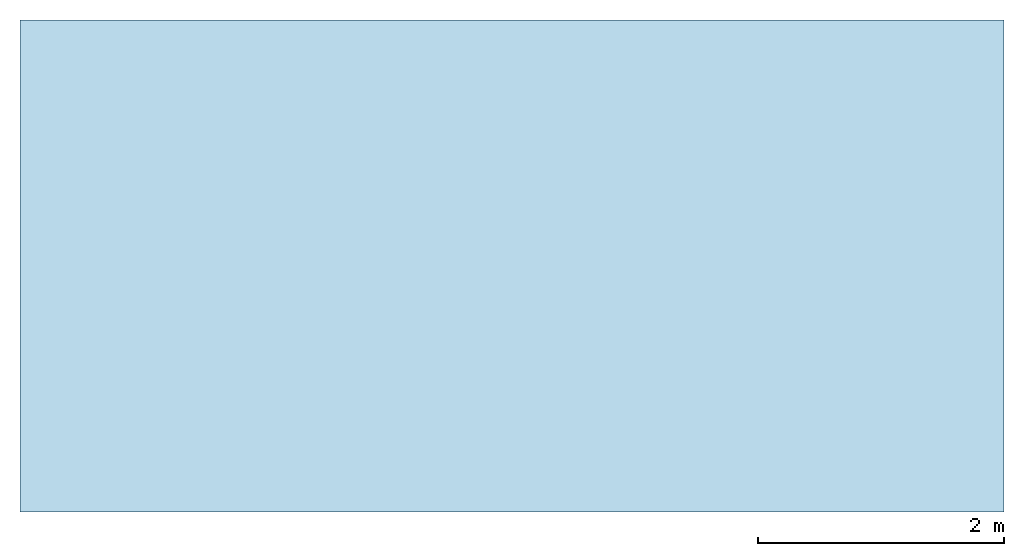
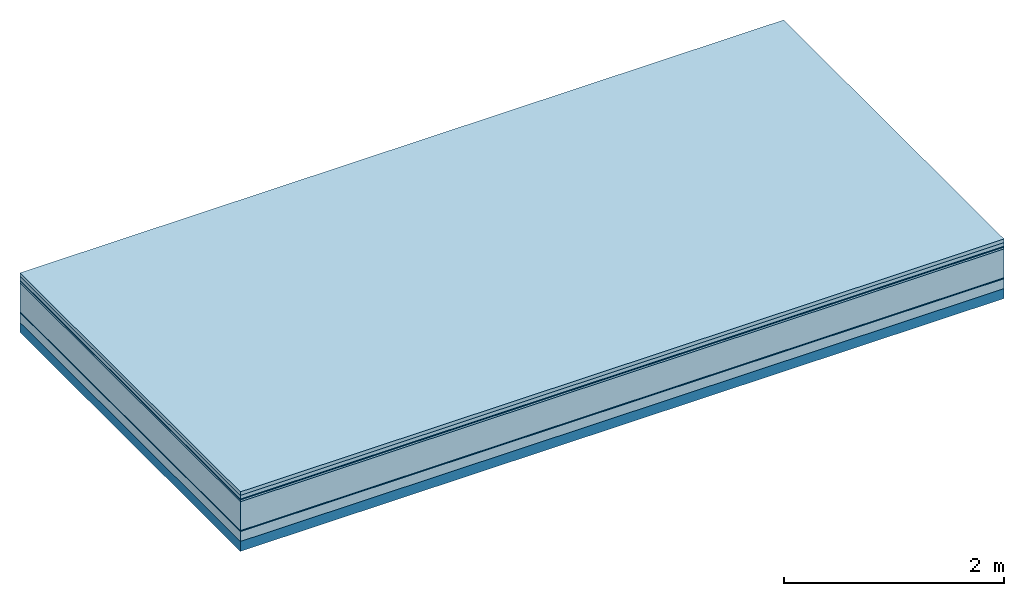
# One storey: 7 plates, 1 member, 1 element without a shape of its own.
"""IFC4 building model written with IfcOpenShell, lengths in metres."""

from ifc_helpers import new_model, si_unit, derived_unit, direction, frame, frame_2d, origin, origin_with_axes, place, context, project, spatial, rectangle, extrude, material, layer, layer_set, type_object, element, aggregate, save


model = new_model("IFC4")

# Units and contexts
plan_context = context("Plan", 3, precision=1e-05, world=origin(), true_north=direction((0.0, 1.0)))
model_context = context("Model", 3, precision=1e-05, world=origin(), true_north=direction((0.0, 1.0)))
ifc_project = project(units=[si_unit("LENGTHUNIT", "METRE"), derived_unit("SOUNDPRESSUREUNIT", [(si_unit("PRESSUREUNIT", "PASCAL", prefix="MICRO"), 0)]), si_unit("ENERGYUNIT", "JOULE", prefix="MEGA"), si_unit("MASSUNIT", "GRAM", prefix="KILO"), derived_unit("THERMALTRANSMITTANCEUNIT", [(si_unit("POWERUNIT", "WATT"), 1), (si_unit("AREAUNIT", "SQUARE_METRE"), -1), (si_unit("THERMODYNAMICTEMPERATUREUNIT", "KELVIN"), -1)]), derived_unit("AREADENSITYUNIT", [(si_unit("MASSUNIT", "GRAM", prefix="KILO"), 1), (si_unit("AREAUNIT", "SQUARE_METRE"), -1)]), derived_unit("USERDEFINED", [(si_unit("ENERGYUNIT", "JOULE", prefix="MEGA"), 1), (si_unit("AREAUNIT", "SQUARE_METRE"), -1)])], contexts=[plan_context, model_context])

# Site, building, storey
site = spatial("IfcSite", under=ifc_project)
building_placement = place(None, origin())
building = spatial("IfcBuilding", under=site, at=building_placement)
storey_placement = place(building_placement, origin())
storey = spatial("IfcBuildingStorey", under=building, at=storey_placement)

# Slab, member, plates
ifc_material_1 = material(Name="Garden plates", Category="02.007")
ifc_layer_1 = layer(ifc_material_1, 0.04, Name="Use and protection layer 3")
ifc_material_2 = material(Name="Gravel 8-16mm", Category="03.011")
ifc_layer_2 = layer(ifc_material_2, 0.04, Name="Use and protection layer 2")
ifc_material_3 = material(Name="Protective layer", Category="09.007")
ifc_layer_3 = layer(ifc_material_3, 0.01, Name="Use and protection layer 1")
ifc_material_4 = material(Name="Bituminous", Category="09.003")
ifc_layer_4 = layer(ifc_material_4, 0.02, Name="Seal")
ifc_material_5 = material(Name="Mineral wool", Category="10.008")
ifc_layer_5 = layer(ifc_material_5, 0.32, Name="Exterior insulation layer 1")
ifc_material_6 = material(Name="Vapor-permeable barrier", Category="09.006")
ifc_layer_6 = layer(ifc_material_6, 0.01, Name="layer / temporary roof")
ifc_material_7 = material(Category="01.002")
ifc_layer_7 = layer(ifc_material_7, 0.11, Name="above 1st layer")
ifc_material_8 = material(Name="Rigid, of the art")
ifc_layer_8 = layer(ifc_material_8, 0.0, Name="Bond")
ifc_layer_9 = layer(None, 0.11, Name="Support")
ifc_layer_set = layer_set([ifc_layer_1, ifc_layer_2, ifc_layer_3, ifc_layer_4, ifc_layer_5, ifc_layer_6, ifc_layer_7, ifc_layer_8, ifc_layer_9])
slab_type = type_object("IfcSlabType", Name="F0086", PredefinedType="NOTDEFINED", material=ifc_layer_set)
slab_placement = place(None, frame((0.0, 0.0, 0.0), z_axis=(0.0, 0.0, -1.0), x_axis=(1.0, 0.0, 0.0)))
slab = element("IfcSlab", 1, at=slab_placement, inside=storey, type_object=slab_type, material=ifc_layer_set, Name="Slab #1")
ifc_material_9 = material(Name="Solid timber panel")
member_placement = place(slab_placement, origin())
member = element("IfcMember", 2, at=member_placement, material=ifc_material_9, Name="Support", context=plan_context, shape_type="SweptSolid", body=[
    extrude(rectangle(XDim=1.0, YDim=0.11, at=frame_2d((0.5, 0.055), x_axis=(1.0, 0.0))), frame((0.0, 4.0, 0.55), z_axis=(0.0, -1.0, 0.0), x_axis=(1.0, 0.0, 0.0)), (0.0, 0.0, 1.0), 4.0),
    extrude(rectangle(XDim=1.0, YDim=0.11, at=frame_2d((0.5, 0.055), x_axis=(1.0, 0.0))), frame((1.0, 4.0, 0.55), z_axis=(0.0, -1.0, 0.0), x_axis=(1.0, 0.0, 0.0)), (0.0, 0.0, 1.0), 4.0),
    extrude(rectangle(XDim=1.0, YDim=0.11, at=frame_2d((0.5, 0.055), x_axis=(1.0, 0.0))), frame((2.0, 4.0, 0.55), z_axis=(0.0, -1.0, 0.0), x_axis=(1.0, 0.0, 0.0)), (0.0, 0.0, 1.0), 4.0),
    extrude(rectangle(XDim=1.0, YDim=0.11, at=frame_2d((0.5, 0.055), x_axis=(1.0, 0.0))), frame((3.0, 4.0, 0.55), z_axis=(0.0, -1.0, 0.0), x_axis=(1.0, 0.0, 0.0)), (0.0, 0.0, 1.0), 4.0),
    extrude(rectangle(XDim=1.0, YDim=0.11, at=frame_2d((0.5, 0.055), x_axis=(1.0, 0.0))), frame((4.0, 4.0, 0.55), z_axis=(0.0, -1.0, 0.0), x_axis=(1.0, 0.0, 0.0)), (0.0, 0.0, 1.0), 4.0),
    extrude(rectangle(XDim=1.0, YDim=0.11, at=frame_2d((0.5, 0.055), x_axis=(1.0, 0.0))), frame((5.0, 4.0, 0.55), z_axis=(0.0, -1.0, 0.0), x_axis=(1.0, 0.0, 0.0)), (0.0, 0.0, 1.0), 4.0),
    extrude(rectangle(XDim=1.0, YDim=0.11, at=frame_2d((0.5, 0.055), x_axis=(1.0, 0.0))), frame((6.0, 4.0, 0.55), z_axis=(0.0, -1.0, 0.0), x_axis=(1.0, 0.0, 0.0)), (0.0, 0.0, 1.0), 4.0),
    extrude(rectangle(XDim=1.0, YDim=0.11, at=frame_2d((0.5, 0.055), x_axis=(1.0, 0.0))), frame((7.0, 4.0, 0.55), z_axis=(0.0, -1.0, 0.0), x_axis=(1.0, 0.0, 0.0)), (0.0, 0.0, 1.0), 4.0),
])
plate_1_placement = place(slab_placement, origin())
plate_1 = element("IfcPlate", 3, at=plate_1_placement, material=ifc_material_1, Name="Use and protection layer 3", context=plan_context, shape_type="SweptSolid", body=[
    extrude(rectangle(XDim=8.0, YDim=4.0, at=frame_2d((4.0, 2.0), x_axis=(1.0, 0.0))), origin_with_axes(), (0.0, 0.0, 1.0), 0.04),
])
plate_2_placement = place(slab_placement, origin())
plate_2 = element("IfcPlate", 4, at=plate_2_placement, material=ifc_material_2, Name="Use and protection layer 2", context=plan_context, shape_type="SweptSolid", body=[
    extrude(rectangle(XDim=8.0, YDim=4.0, at=frame_2d((4.0, 2.0), x_axis=(1.0, 0.0))), frame((0.0, 0.0, 0.04), z_axis=(0.0, 0.0, 1.0), x_axis=(1.0, 0.0, 0.0)), (0.0, 0.0, 1.0), 0.04),
])
plate_3_placement = place(slab_placement, origin())
plate_3 = element("IfcPlate", 5, at=plate_3_placement, material=ifc_material_3, Name="Use and protection layer 1", context=plan_context, shape_type="SweptSolid", body=[
    extrude(rectangle(XDim=8.0, YDim=4.0, at=frame_2d((4.0, 2.0), x_axis=(1.0, 0.0))), frame((0.0, 0.0, 0.08), z_axis=(0.0, 0.0, 1.0), x_axis=(1.0, 0.0, 0.0)), (0.0, 0.0, 1.0), 0.01),
])
plate_4_placement = place(slab_placement, origin())
plate_4 = element("IfcPlate", 6, at=plate_4_placement, material=ifc_material_4, Name="Seal", context=plan_context, shape_type="SweptSolid", body=[
    extrude(rectangle(XDim=8.0, YDim=4.0, at=frame_2d((4.0, 2.0), x_axis=(1.0, 0.0))), frame((0.0, 0.0, 0.09), z_axis=(0.0, 0.0, 1.0), x_axis=(1.0, 0.0, 0.0)), (0.0, 0.0, 1.0), 0.02),
])
plate_5_placement = place(slab_placement, origin())
plate_5 = element("IfcPlate", 7, at=plate_5_placement, material=ifc_material_5, Name="Exterior insulation layer 1", context=plan_context, shape_type="SweptSolid", body=[
    extrude(rectangle(XDim=8.0, YDim=4.0, at=frame_2d((4.0, 2.0), x_axis=(1.0, 0.0))), frame((0.0, 0.0, 0.11), z_axis=(0.0, 0.0, 1.0), x_axis=(1.0, 0.0, 0.0)), (0.0, 0.0, 1.0), 0.32),
])
plate_6_placement = place(slab_placement, origin())
plate_6 = element("IfcPlate", 8, at=plate_6_placement, material=ifc_material_6, Name="layer / temporary roof", context=plan_context, shape_type="SweptSolid", body=[
    extrude(rectangle(XDim=8.0, YDim=4.0, at=frame_2d((4.0, 2.0), x_axis=(1.0, 0.0))), frame((0.0, 0.0, 0.43), z_axis=(0.0, 0.0, 1.0), x_axis=(1.0, 0.0, 0.0)), (0.0, 0.0, 1.0), 0.01),
])
plate_7_placement = place(slab_placement, origin())
plate_7 = element("IfcPlate", 9, at=plate_7_placement, material=ifc_material_7, Name="above 1st layer", context=plan_context, shape_type="SweptSolid", body=[
    extrude(rectangle(XDim=8.0, YDim=4.0, at=frame_2d((4.0, 2.0), x_axis=(1.0, 0.0))), frame((0.0, 0.0, 0.44), z_axis=(0.0, 0.0, 1.0), x_axis=(1.0, 0.0, 0.0)), (0.0, 0.0, 1.0), 0.11),
])
aggregate(slab, [plate_1, plate_2, plate_3, plate_4, plate_5, plate_6, plate_7, member])

save(model, "model.ifc")
